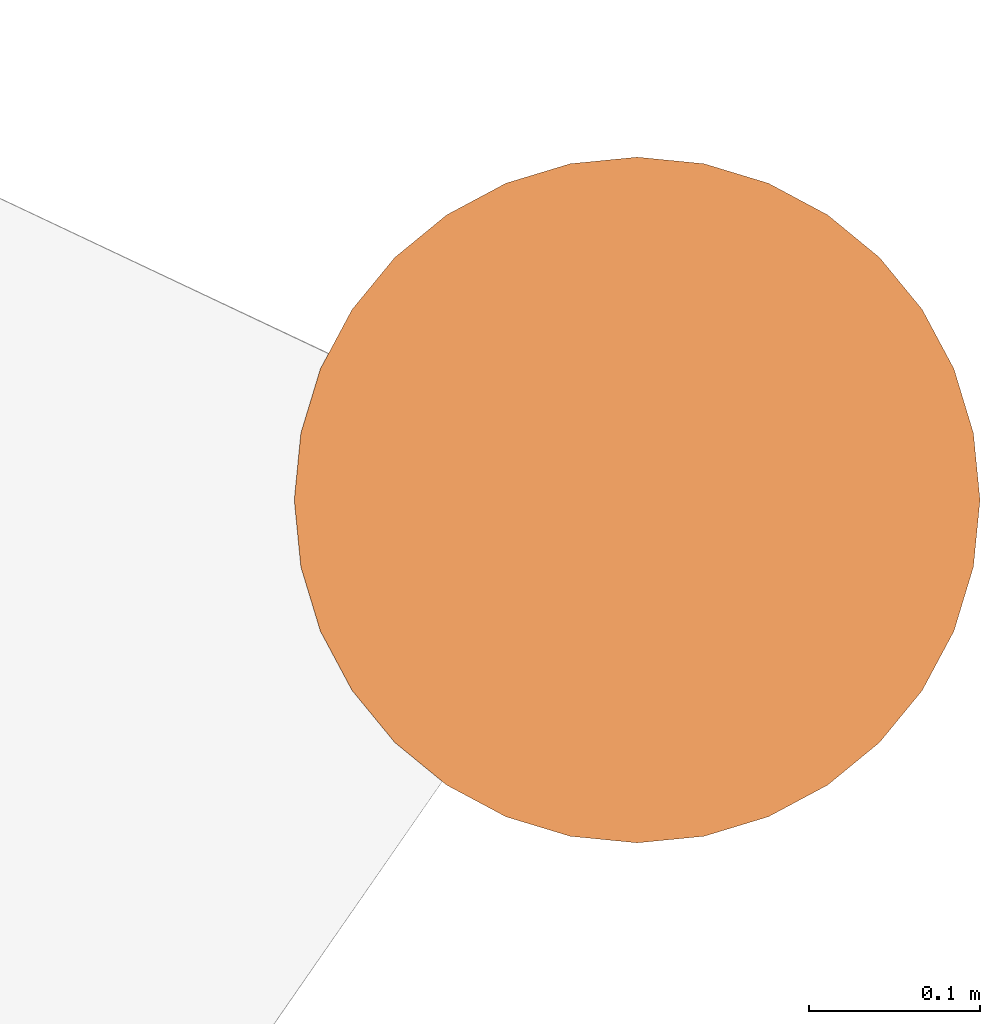
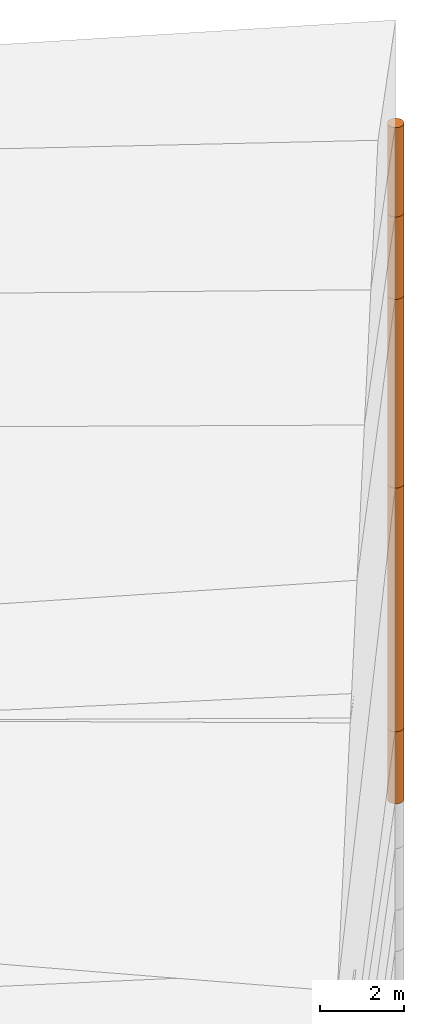
# One storey, part 22 of 24: 5 geographic elements.
"""IFC4 building model written with IfcOpenShell, lengths in metres."""

from ifc_helpers import new_model, entity, si_unit, converted_unit, frame, origin_with_axes, origin_2d_with_axis, place, context, subcontext, project, spatial, polygons, element, save


model = new_model("IFC4")

# Units and contexts
model_context = context("Model", 3, precision=1e-05, world=origin_with_axes())
plan_context = context("Plan", 2, precision=1e-05, world=origin_2d_with_axis())
body_context = subcontext(model_context, "Body", "Model", "MODEL_VIEW")
ifc_project = project(units=[converted_unit("PLANEANGLEUNIT", "degree", entity("IfcReal", 0.0174532925199433), si_unit("PLANEANGLEUNIT", "RADIAN"), dimensions=[0, 0, 0, 0, 0, 0, 0]), si_unit("AREAUNIT", "SQUARE_METRE"), si_unit("VOLUMEUNIT", "CUBIC_METRE"), si_unit("LENGTHUNIT", "METRE")], contexts=[model_context, plan_context])

# Site, building, storey
site_placement = place(None, origin_with_axes())
site = spatial("IfcSite", under=ifc_project, at=site_placement)
building_placement = place(site_placement, origin_with_axes())
building = spatial("IfcBuilding", under=site, at=building_placement, Name="Building")
storey_placement = place(building_placement, origin_with_axes())
storey = spatial("IfcBuildingStorey", under=building, at=storey_placement, Name="Storey")

# Geographic elements
geographic_element_1_placement = place(storey_placement, frame((50.0999984741211, 76.4000015258789, -2.14999914169312), z_axis=(0.0, 0.0, 1.0), x_axis=(1.0, 0.0, 0.0)))
element("IfcGeographicElement", 1, at=geographic_element_1_placement, inside=storey, PredefinedType="NOTDEFINED", context=body_context, shape_type="Tessellation", body=[
    polygons([(0.0, 0.0, -1.04999983310699), (0.0390180610120296, 0.196157038211823, -1.04999983310699), (0.0, 0.199999988079071, -1.04999983310699), (0.0, 0.0, 1.04999983310699), (0.0, 0.199999988079071, 1.04999983310699), (0.0390180610120296, 0.196157038211823, 1.04999983310699), (0.0765366926789284, 0.18477588891983, -1.04999983310699), (0.0765366926789284, 0.18477588891983, 1.04999983310699), (0.111114047467709, 0.166293919086456, -1.04999983310699), (0.111114047467709, 0.166293919086456, 1.04999983310699), (0.141421362757683, 0.141421362757683, -1.04999983310699), (0.141421362757683, 0.141421362757683, 1.04999983310699), (0.166293919086456, 0.111114047467709, -1.04999983310699), (0.166293919086456, 0.111114047467709, 1.04999983310699), (0.18477588891983, 0.0765366926789284, -1.04999983310699), (0.18477588891983, 0.0765366926789284, 1.04999983310699), (0.196157038211823, 0.0390180610120296, -1.04999983310699), (0.196157038211823, 0.0390180610120296, 1.04999983310699), (0.199999988079071, 0.0, -1.04999983310699), (0.199999988079071, 0.0, 1.04999983310699), (0.196157038211823, -0.0390180610120296, -1.04999983310699), (0.196157038211823, -0.0390180610120296, 1.04999983310699), (0.18477588891983, -0.0765366926789284, -1.04999983310699), (0.18477588891983, -0.0765366926789284, 1.04999983310699), (0.166293919086456, -0.111114047467709, -1.04999983310699), (0.166293919086456, -0.111114047467709, 1.04999983310699), (0.141421362757683, -0.141421362757683, -1.04999983310699), (0.141421362757683, -0.141421362757683, 1.04999983310699), (0.111114047467709, -0.166293919086456, -1.04999983310699), (0.111114047467709, -0.166293919086456, 1.04999983310699), (0.0765366926789284, -0.18477588891983, -1.04999983310699), (0.0765366926789284, -0.18477588891983, 1.04999983310699), (0.0390180610120296, -0.196157038211823, -1.04999983310699), (0.0390180610120296, -0.196157038211823, 1.04999983310699), (0.0, -0.199999988079071, -1.04999983310699), (0.0, -0.199999988079071, 1.04999983310699), (-0.0390180610120296, -0.196157038211823, -1.04999983310699), (-0.0390180610120296, -0.196157038211823, 1.04999983310699), (-0.0765366926789284, -0.18477588891983, -1.04999983310699), (-0.0765366926789284, -0.18477588891983, 1.04999983310699), (-0.111114047467709, -0.166293919086456, -1.04999983310699), (-0.111114047467709, -0.166293919086456, 1.04999983310699), (-0.141421362757683, -0.141421362757683, -1.04999983310699), (-0.141421362757683, -0.141421362757683, 1.04999983310699), (-0.166293919086456, -0.111114047467709, -1.04999983310699), (-0.166293919086456, -0.111114047467709, 1.04999983310699), (-0.18477588891983, -0.0765366926789284, -1.04999983310699), (-0.18477588891983, -0.0765366926789284, 1.04999983310699), (-0.196157038211823, -0.0390180610120296, -1.04999983310699), (-0.196157038211823, -0.0390180610120296, 1.04999983310699), (-0.199999988079071, 0.0, -1.04999983310699), (-0.199999988079071, 0.0, 1.04999983310699), (-0.196157038211823, 0.0390180610120296, -1.04999983310699), (-0.196157038211823, 0.0390180610120296, 1.04999983310699), (-0.18477588891983, 0.0765366926789284, -1.04999983310699), (-0.18477588891983, 0.0765366926789284, 1.04999983310699), (-0.166293919086456, 0.111114047467709, -1.04999983310699), (-0.166293919086456, 0.111114047467709, 1.04999983310699), (-0.141421362757683, 0.141421362757683, -1.04999983310699), (-0.141421362757683, 0.141421362757683, 1.04999983310699), (-0.111114047467709, 0.166293919086456, -1.04999983310699), (-0.111114047467709, 0.166293919086456, 1.04999983310699), (-0.0765366926789284, 0.18477588891983, -1.04999983310699), (-0.0765366926789284, 0.18477588891983, 1.04999983310699), (-0.0390180610120296, 0.196157038211823, -1.04999983310699), (-0.0390180610120296, 0.196157038211823, 1.04999983310699)], [[[3, 2, 1]], [[6, 5, 4]], [[34, 36, 35, 33]], [[2, 7, 1]], [[8, 6, 4]], [[54, 56, 55, 53]], [[7, 9, 1]], [[10, 8, 4]], [[10, 12, 11, 9]], [[9, 11, 1]], [[12, 10, 4]], [[11, 13, 1]], [[12, 4, 14]], [[46, 48, 47, 45]], [[1, 13, 15]], [[4, 16, 14]], [[28, 30, 29, 27]], [[1, 15, 17]], [[16, 4, 18]], [[38, 40, 39, 37]], [[1, 17, 19]], [[4, 20, 18]], [[20, 22, 21, 19]], [[1, 19, 21]], [[20, 4, 22]], [[22, 24, 23, 21]], [[1, 21, 23]], [[22, 4, 24]], [[5, 6, 2, 3]], [[1, 23, 25]], [[24, 4, 26]], [[58, 60, 59, 57]], [[1, 25, 27]], [[26, 4, 28]], [[24, 26, 25, 23]], [[1, 27, 29]], [[28, 4, 30]], [[8, 10, 9, 7]], [[1, 29, 31]], [[4, 32, 30]], [[60, 62, 61, 59]], [[1, 31, 33]], [[4, 34, 32]], [[64, 66, 65, 63]], [[1, 33, 35]], [[4, 36, 34]], [[26, 28, 27, 25]], [[1, 35, 37]], [[4, 38, 36]], [[32, 34, 33, 31]], [[1, 37, 39]], [[4, 40, 38]], [[36, 38, 37, 35]], [[1, 39, 41]], [[4, 42, 40]], [[42, 44, 43, 41]], [[43, 1, 41]], [[4, 44, 42]], [[44, 46, 45, 43]], [[45, 1, 43]], [[4, 46, 44]], [[12, 14, 13, 11]], [[47, 1, 45]], [[48, 46, 4]], [[14, 16, 15, 13]], [[49, 1, 47]], [[4, 50, 48]], [[50, 52, 51, 49]], [[51, 1, 49]], [[52, 50, 4]], [[66, 5, 3, 65]], [[51, 53, 1]], [[4, 54, 52]], [[6, 8, 7, 2]], [[55, 1, 53]], [[4, 56, 54]], [[16, 18, 17, 15]], [[55, 57, 1]], [[4, 58, 56]], [[30, 32, 31, 29]], [[59, 1, 57]], [[60, 58, 4]], [[56, 58, 57, 55]], [[59, 61, 1]], [[62, 60, 4]], [[62, 64, 63, 61]], [[61, 63, 1]], [[64, 62, 4]], [[40, 42, 41, 39]], [[63, 65, 1]], [[66, 64, 4]], [[18, 20, 19, 17]], [[65, 3, 1]], [[5, 66, 4]], [[52, 54, 53, 51]], [[48, 50, 49, 47]]]),
])
geographic_element_2_placement = place(storey_placement, frame((50.0999984741211, 76.4000015258789, 2.45000076293945), z_axis=(0.0, 0.0, 1.0), x_axis=(1.0, 0.0, 0.0)))
element("IfcGeographicElement", 2, at=geographic_element_2_placement, inside=storey, PredefinedType="NOTDEFINED", context=body_context, shape_type="Tessellation", body=[
    polygons([(0.0, 0.0, -3.54999971389771), (0.0390180610120296, 0.196157038211823, -3.54999971389771), (0.0, 0.199999988079071, -3.54999971389771), (0.0, 0.0, 3.54999971389771), (0.0, 0.199999988079071, 3.54999971389771), (0.0390180610120296, 0.196157038211823, 3.54999971389771), (0.0765366926789284, 0.18477588891983, -3.54999971389771), (0.0765366926789284, 0.18477588891983, 3.54999971389771), (0.111114047467709, 0.166293919086456, -3.54999971389771), (0.111114047467709, 0.166293919086456, 3.54999971389771), (0.141421362757683, 0.141421362757683, -3.54999971389771), (0.141421362757683, 0.141421362757683, 3.54999971389771), (0.166293919086456, 0.111114047467709, -3.54999971389771), (0.166293919086456, 0.111114047467709, 3.54999971389771), (0.18477588891983, 0.0765366926789284, -3.54999971389771), (0.18477588891983, 0.0765366926789284, 3.54999971389771), (0.196157038211823, 0.0390180610120296, -3.54999971389771), (0.196157038211823, 0.0390180610120296, 3.54999971389771), (0.199999988079071, 0.0, -3.54999971389771), (0.199999988079071, 0.0, 3.54999971389771), (0.196157038211823, -0.0390180610120296, -3.54999971389771), (0.196157038211823, -0.0390180610120296, 3.54999971389771), (0.18477588891983, -0.0765366926789284, -3.54999971389771), (0.18477588891983, -0.0765366926789284, 3.54999971389771), (0.166293919086456, -0.111114047467709, -3.54999971389771), (0.166293919086456, -0.111114047467709, 3.54999971389771), (0.141421362757683, -0.141421362757683, -3.54999971389771), (0.141421362757683, -0.141421362757683, 3.54999971389771), (0.111114047467709, -0.166293919086456, -3.54999971389771), (0.111114047467709, -0.166293919086456, 3.54999971389771), (0.0765366926789284, -0.18477588891983, -3.54999971389771), (0.0765366926789284, -0.18477588891983, 3.54999971389771), (0.0390180610120296, -0.196157038211823, -3.54999971389771), (0.0390180610120296, -0.196157038211823, 3.54999971389771), (0.0, -0.199999988079071, -3.54999971389771), (0.0, -0.199999988079071, 3.54999971389771), (-0.0390180610120296, -0.196157038211823, -3.54999971389771), (-0.0390180610120296, -0.196157038211823, 3.54999971389771), (-0.0765366926789284, -0.18477588891983, -3.54999971389771), (-0.0765366926789284, -0.18477588891983, 3.54999971389771), (-0.111114047467709, -0.166293919086456, -3.54999971389771), (-0.111114047467709, -0.166293919086456, 3.54999971389771), (-0.141421362757683, -0.141421362757683, -3.54999971389771), (-0.141421362757683, -0.141421362757683, 3.54999971389771), (-0.166293919086456, -0.111114047467709, -3.54999971389771), (-0.166293919086456, -0.111114047467709, 3.54999971389771), (-0.18477588891983, -0.0765366926789284, -3.54999971389771), (-0.18477588891983, -0.0765366926789284, 3.54999971389771), (-0.196157038211823, -0.0390180610120296, -3.54999971389771), (-0.196157038211823, -0.0390180610120296, 3.54999971389771), (-0.199999988079071, 0.0, -3.54999971389771), (-0.199999988079071, 0.0, 3.54999971389771), (-0.196157038211823, 0.0390180610120296, -3.54999971389771), (-0.196157038211823, 0.0390180610120296, 3.54999971389771), (-0.18477588891983, 0.0765366926789284, -3.54999971389771), (-0.18477588891983, 0.0765366926789284, 3.54999971389771), (-0.166293919086456, 0.111114047467709, -3.54999971389771), (-0.166293919086456, 0.111114047467709, 3.54999971389771), (-0.141421362757683, 0.141421362757683, -3.54999971389771), (-0.141421362757683, 0.141421362757683, 3.54999971389771), (-0.111114047467709, 0.166293919086456, -3.54999971389771), (-0.111114047467709, 0.166293919086456, 3.54999971389771), (-0.0765366926789284, 0.18477588891983, -3.54999971389771), (-0.0765366926789284, 0.18477588891983, 3.54999971389771), (-0.0390180610120296, 0.196157038211823, -3.54999971389771), (-0.0390180610120296, 0.196157038211823, 3.54999971389771)], [[[3, 2, 1]], [[6, 5, 4]], [[32, 34, 33, 31]], [[2, 7, 1]], [[8, 6, 4]], [[64, 66, 65, 63]], [[7, 9, 1]], [[10, 8, 4]], [[9, 11, 1]], [[12, 10, 4]], [[40, 42, 41, 39]], [[1, 11, 13]], [[12, 4, 14]], [[10, 12, 11, 9]], [[1, 13, 15]], [[14, 4, 16]], [[12, 14, 13, 11]], [[1, 15, 17]], [[16, 4, 18]], [[18, 20, 19, 17]], [[1, 17, 19]], [[4, 20, 18]], [[20, 22, 21, 19]], [[1, 19, 21]], [[20, 4, 22]], [[22, 24, 23, 21]], [[1, 21, 23]], [[4, 24, 22]], [[54, 56, 55, 53]], [[1, 23, 25]], [[4, 26, 24]], [[56, 58, 57, 55]], [[1, 25, 27]], [[4, 28, 26]], [[24, 26, 25, 23]], [[1, 27, 29]], [[28, 4, 30]], [[26, 28, 27, 25]], [[1, 29, 31]], [[4, 32, 30]], [[46, 48, 47, 45]], [[1, 31, 33]], [[4, 34, 32]], [[36, 38, 37, 35]], [[1, 33, 35]], [[4, 36, 34]], [[42, 44, 43, 41]], [[1, 35, 37]], [[4, 38, 36]], [[38, 40, 39, 37]], [[1, 37, 39]], [[4, 40, 38]], [[34, 36, 35, 33]], [[1, 39, 41]], [[4, 42, 40]], [[8, 10, 9, 7]], [[43, 1, 41]], [[4, 44, 42]], [[44, 46, 45, 43]], [[43, 45, 1]], [[4, 46, 44]], [[30, 32, 31, 29]], [[45, 47, 1]], [[4, 48, 46]], [[28, 30, 29, 27]], [[47, 49, 1]], [[4, 50, 48]], [[5, 6, 2, 3]], [[51, 1, 49]], [[52, 50, 4]], [[48, 50, 49, 47]], [[51, 53, 1]], [[4, 54, 52]], [[50, 52, 51, 49]], [[55, 1, 53]], [[56, 54, 4]], [[52, 54, 53, 51]], [[57, 1, 55]], [[58, 56, 4]], [[58, 60, 59, 57]], [[59, 1, 57]], [[60, 58, 4]], [[60, 62, 61, 59]], [[59, 61, 1]], [[62, 60, 4]], [[62, 64, 63, 61]], [[61, 63, 1]], [[64, 62, 4]], [[14, 16, 15, 13]], [[63, 65, 1]], [[66, 64, 4]], [[16, 18, 17, 15]], [[65, 3, 1]], [[5, 66, 4]], [[6, 8, 7, 2]], [[66, 5, 3, 65]]]),
])
geographic_element_3_placement = place(storey_placement, frame((50.0999984741211, 76.4000015258789, 8.75000095367432), z_axis=(0.0, 0.0, 1.0), x_axis=(1.0, 0.0, 0.0)))
element("IfcGeographicElement", 3, at=geographic_element_3_placement, inside=storey, PredefinedType="NOTDEFINED", context=body_context, shape_type="Tessellation", body=[
    polygons([(0.0, 0.0, -2.74999976158142), (0.0390180610120296, 0.196157038211823, -2.74999976158142), (0.0, 0.199999988079071, -2.74999976158142), (0.0, 0.0, 2.74999976158142), (0.0, 0.199999988079071, 2.74999976158142), (0.0390180610120296, 0.196157038211823, 2.74999976158142), (0.0765366926789284, 0.18477588891983, -2.74999976158142), (0.0765366926789284, 0.18477588891983, 2.74999976158142), (0.111114047467709, 0.166293919086456, -2.74999976158142), (0.111114047467709, 0.166293919086456, 2.74999976158142), (0.141421362757683, 0.141421362757683, -2.74999976158142), (0.141421362757683, 0.141421362757683, 2.74999976158142), (0.166293919086456, 0.111114047467709, -2.74999976158142), (0.166293919086456, 0.111114047467709, 2.74999976158142), (0.18477588891983, 0.0765366926789284, -2.74999976158142), (0.18477588891983, 0.0765366926789284, 2.74999976158142), (0.196157038211823, 0.0390180610120296, -2.74999976158142), (0.196157038211823, 0.0390180610120296, 2.74999976158142), (0.199999988079071, 0.0, -2.74999976158142), (0.199999988079071, 0.0, 2.74999976158142), (0.196157038211823, -0.0390180610120296, -2.74999976158142), (0.196157038211823, -0.0390180610120296, 2.74999976158142), (0.18477588891983, -0.0765366926789284, -2.74999976158142), (0.18477588891983, -0.0765366926789284, 2.74999976158142), (0.166293919086456, -0.111114047467709, -2.74999976158142), (0.166293919086456, -0.111114047467709, 2.74999976158142), (0.141421362757683, -0.141421362757683, -2.74999976158142), (0.141421362757683, -0.141421362757683, 2.74999976158142), (0.111114047467709, -0.166293919086456, -2.74999976158142), (0.111114047467709, -0.166293919086456, 2.74999976158142), (0.0765366926789284, -0.18477588891983, -2.74999976158142), (0.0765366926789284, -0.18477588891983, 2.74999976158142), (0.0390180610120296, -0.196157038211823, -2.74999976158142), (0.0390180610120296, -0.196157038211823, 2.74999976158142), (0.0, -0.199999988079071, -2.74999976158142), (0.0, -0.199999988079071, 2.74999976158142), (-0.0390180610120296, -0.196157038211823, -2.74999976158142), (-0.0390180610120296, -0.196157038211823, 2.74999976158142), (-0.0765366926789284, -0.18477588891983, -2.74999976158142), (-0.0765366926789284, -0.18477588891983, 2.74999976158142), (-0.111114047467709, -0.166293919086456, -2.74999976158142), (-0.111114047467709, -0.166293919086456, 2.74999976158142), (-0.141421362757683, -0.141421362757683, -2.74999976158142), (-0.141421362757683, -0.141421362757683, 2.74999976158142), (-0.166293919086456, -0.111114047467709, -2.74999976158142), (-0.166293919086456, -0.111114047467709, 2.74999976158142), (-0.18477588891983, -0.0765366926789284, -2.74999976158142), (-0.18477588891983, -0.0765366926789284, 2.74999976158142), (-0.196157038211823, -0.0390180610120296, -2.74999976158142), (-0.196157038211823, -0.0390180610120296, 2.74999976158142), (-0.199999988079071, 0.0, -2.74999976158142), (-0.199999988079071, 0.0, 2.74999976158142), (-0.196157038211823, 0.0390180610120296, -2.74999976158142), (-0.196157038211823, 0.0390180610120296, 2.74999976158142), (-0.18477588891983, 0.0765366926789284, -2.74999976158142), (-0.18477588891983, 0.0765366926789284, 2.74999976158142), (-0.166293919086456, 0.111114047467709, -2.74999976158142), (-0.166293919086456, 0.111114047467709, 2.74999976158142), (-0.141421362757683, 0.141421362757683, -2.74999976158142), (-0.141421362757683, 0.141421362757683, 2.74999976158142), (-0.111114047467709, 0.166293919086456, -2.74999976158142), (-0.111114047467709, 0.166293919086456, 2.74999976158142), (-0.0765366926789284, 0.18477588891983, -2.74999976158142), (-0.0765366926789284, 0.18477588891983, 2.74999976158142), (-0.0390180610120296, 0.196157038211823, -2.74999976158142), (-0.0390180610120296, 0.196157038211823, 2.74999976158142)], [[[3, 2, 1]], [[6, 5, 4]], [[28, 30, 29, 27]], [[2, 7, 1]], [[8, 6, 4]], [[64, 66, 65, 63]], [[7, 9, 1]], [[10, 8, 4]], [[9, 11, 1]], [[12, 10, 4]], [[6, 8, 7, 2]], [[1, 11, 13]], [[12, 4, 14]], [[66, 5, 3, 65]], [[1, 13, 15]], [[4, 16, 14]], [[12, 14, 13, 11]], [[1, 15, 17]], [[16, 4, 18]], [[14, 16, 15, 13]], [[1, 17, 19]], [[4, 20, 18]], [[16, 18, 17, 15]], [[1, 19, 21]], [[20, 4, 22]], [[18, 20, 19, 17]], [[1, 21, 23]], [[4, 24, 22]], [[20, 22, 21, 19]], [[1, 23, 25]], [[4, 26, 24]], [[22, 24, 23, 21]], [[1, 25, 27]], [[4, 28, 26]], [[24, 26, 25, 23]], [[1, 27, 29]], [[28, 4, 30]], [[26, 28, 27, 25]], [[1, 29, 31]], [[4, 32, 30]], [[5, 6, 2, 3]], [[1, 31, 33]], [[4, 34, 32]], [[30, 32, 31, 29]], [[1, 33, 35]], [[4, 36, 34]], [[8, 10, 9, 7]], [[1, 35, 37]], [[4, 38, 36]], [[32, 34, 33, 31]], [[1, 37, 39]], [[4, 40, 38]], [[36, 38, 37, 35]], [[1, 39, 41]], [[4, 42, 40]], [[38, 40, 39, 37]], [[43, 1, 41]], [[4, 44, 42]], [[40, 42, 41, 39]], [[43, 45, 1]], [[4, 46, 44]], [[42, 44, 43, 41]], [[45, 47, 1]], [[48, 46, 4]], [[44, 46, 45, 43]], [[47, 49, 1]], [[4, 50, 48]], [[46, 48, 47, 45]], [[51, 1, 49]], [[52, 50, 4]], [[48, 50, 49, 47]], [[51, 53, 1]], [[4, 54, 52]], [[50, 52, 51, 49]], [[55, 1, 53]], [[56, 54, 4]], [[52, 54, 53, 51]], [[55, 57, 1]], [[58, 56, 4]], [[54, 56, 55, 53]], [[59, 1, 57]], [[60, 58, 4]], [[56, 58, 57, 55]], [[59, 61, 1]], [[62, 60, 4]], [[58, 60, 59, 57]], [[61, 63, 1]], [[64, 62, 4]], [[60, 62, 61, 59]], [[63, 65, 1]], [[66, 64, 4]], [[62, 64, 63, 61]], [[65, 3, 1]], [[5, 66, 4]], [[34, 36, 35, 33]], [[10, 12, 11, 9]]]),
])
geographic_element_4_placement = place(storey_placement, frame((50.0999984741211, 76.4000015258789, 12.7000007629395), z_axis=(0.0, 0.0, 1.0), x_axis=(1.0, 0.0, 0.0)))
element("IfcGeographicElement", 4, at=geographic_element_4_placement, inside=storey, PredefinedType="NOTDEFINED", context=body_context, shape_type="Tessellation", body=[
    polygons([(0.0, 0.0, -1.19999992847443), (0.0390180610120296, 0.196157038211823, -1.19999992847443), (0.0, 0.199999988079071, -1.19999992847443), (0.0, 0.0, 1.19999992847443), (0.0, 0.199999988079071, 1.19999992847443), (0.0390180610120296, 0.196157038211823, 1.19999992847443), (0.0765366926789284, 0.18477588891983, -1.19999992847443), (0.0765366926789284, 0.18477588891983, 1.19999992847443), (0.111114047467709, 0.166293919086456, -1.19999992847443), (0.111114047467709, 0.166293919086456, 1.19999992847443), (0.141421362757683, 0.141421362757683, -1.19999992847443), (0.141421362757683, 0.141421362757683, 1.19999992847443), (0.166293919086456, 0.111114047467709, -1.19999992847443), (0.166293919086456, 0.111114047467709, 1.19999992847443), (0.18477588891983, 0.0765366926789284, -1.19999992847443), (0.18477588891983, 0.0765366926789284, 1.19999992847443), (0.196157038211823, 0.0390180610120296, -1.19999992847443), (0.196157038211823, 0.0390180610120296, 1.19999992847443), (0.199999988079071, 0.0, -1.19999992847443), (0.199999988079071, 0.0, 1.19999992847443), (0.196157038211823, -0.0390180610120296, -1.19999992847443), (0.196157038211823, -0.0390180610120296, 1.19999992847443), (0.18477588891983, -0.0765366926789284, -1.19999992847443), (0.18477588891983, -0.0765366926789284, 1.19999992847443), (0.166293919086456, -0.111114047467709, -1.19999992847443), (0.166293919086456, -0.111114047467709, 1.19999992847443), (0.141421362757683, -0.141421362757683, -1.19999992847443), (0.141421362757683, -0.141421362757683, 1.19999992847443), (0.111114047467709, -0.166293919086456, -1.19999992847443), (0.111114047467709, -0.166293919086456, 1.19999992847443), (0.0765366926789284, -0.18477588891983, -1.19999992847443), (0.0765366926789284, -0.18477588891983, 1.19999992847443), (0.0390180610120296, -0.196157038211823, -1.19999992847443), (0.0390180610120296, -0.196157038211823, 1.19999992847443), (0.0, -0.199999988079071, -1.19999992847443), (0.0, -0.199999988079071, 1.19999992847443), (-0.0390180610120296, -0.196157038211823, -1.19999992847443), (-0.0390180610120296, -0.196157038211823, 1.19999992847443), (-0.0765366926789284, -0.18477588891983, -1.19999992847443), (-0.0765366926789284, -0.18477588891983, 1.19999992847443), (-0.111114047467709, -0.166293919086456, -1.19999992847443), (-0.111114047467709, -0.166293919086456, 1.19999992847443), (-0.141421362757683, -0.141421362757683, -1.19999992847443), (-0.141421362757683, -0.141421362757683, 1.19999992847443), (-0.166293919086456, -0.111114047467709, -1.19999992847443), (-0.166293919086456, -0.111114047467709, 1.19999992847443), (-0.18477588891983, -0.0765366926789284, -1.19999992847443), (-0.18477588891983, -0.0765366926789284, 1.19999992847443), (-0.196157038211823, -0.0390180610120296, -1.19999992847443), (-0.196157038211823, -0.0390180610120296, 1.19999992847443), (-0.199999988079071, 0.0, -1.19999992847443), (-0.199999988079071, 0.0, 1.19999992847443), (-0.196157038211823, 0.0390180610120296, -1.19999992847443), (-0.196157038211823, 0.0390180610120296, 1.19999992847443), (-0.18477588891983, 0.0765366926789284, -1.19999992847443), (-0.18477588891983, 0.0765366926789284, 1.19999992847443), (-0.166293919086456, 0.111114047467709, -1.19999992847443), (-0.166293919086456, 0.111114047467709, 1.19999992847443), (-0.141421362757683, 0.141421362757683, -1.19999992847443), (-0.141421362757683, 0.141421362757683, 1.19999992847443), (-0.111114047467709, 0.166293919086456, -1.19999992847443), (-0.111114047467709, 0.166293919086456, 1.19999992847443), (-0.0765366926789284, 0.18477588891983, -1.19999992847443), (-0.0765366926789284, 0.18477588891983, 1.19999992847443), (-0.0390180610120296, 0.196157038211823, -1.19999992847443), (-0.0390180610120296, 0.196157038211823, 1.19999992847443)], [[[3, 2, 1]], [[6, 5, 4]], [[62, 64, 63, 61]], [[2, 7, 1]], [[8, 6, 4]], [[30, 32, 31, 29]], [[7, 9, 1]], [[10, 8, 4]], [[10, 12, 11, 9]], [[9, 11, 1]], [[12, 10, 4]], [[11, 13, 1]], [[12, 4, 14]], [[66, 5, 3, 65]], [[1, 13, 15]], [[4, 16, 14]], [[42, 44, 43, 41]], [[1, 15, 17]], [[16, 4, 18]], [[48, 50, 49, 47]], [[1, 17, 19]], [[4, 20, 18]], [[16, 18, 17, 15]], [[1, 19, 21]], [[20, 4, 22]], [[50, 52, 51, 49]], [[1, 21, 23]], [[22, 4, 24]], [[54, 56, 55, 53]], [[1, 23, 25]], [[4, 26, 24]], [[56, 58, 57, 55]], [[27, 1, 25]], [[26, 4, 28]], [[58, 60, 59, 57]], [[1, 27, 29]], [[28, 4, 30]], [[60, 62, 61, 59]], [[1, 29, 31]], [[4, 32, 30]], [[64, 66, 65, 63]], [[1, 31, 33]], [[4, 34, 32]], [[6, 8, 7, 2]], [[1, 33, 35]], [[4, 36, 34]], [[8, 10, 9, 7]], [[1, 35, 37]], [[4, 38, 36]], [[32, 34, 33, 31]], [[1, 37, 39]], [[4, 40, 38]], [[36, 38, 37, 35]], [[1, 39, 41]], [[4, 42, 40]], [[46, 48, 47, 45]], [[43, 1, 41]], [[4, 44, 42]], [[34, 36, 35, 33]], [[45, 1, 43]], [[46, 44, 4]], [[14, 16, 15, 13]], [[45, 47, 1]], [[48, 46, 4]], [[44, 46, 45, 43]], [[49, 1, 47]], [[4, 50, 48]], [[40, 42, 41, 39]], [[51, 1, 49]], [[52, 50, 4]], [[18, 20, 19, 17]], [[51, 53, 1]], [[4, 54, 52]], [[20, 22, 21, 19]], [[55, 1, 53]], [[4, 56, 54]], [[52, 54, 53, 51]], [[55, 57, 1]], [[58, 56, 4]], [[22, 24, 23, 21]], [[57, 59, 1]], [[60, 58, 4]], [[24, 26, 25, 23]], [[59, 61, 1]], [[62, 60, 4]], [[26, 28, 27, 25]], [[61, 63, 1]], [[64, 62, 4]], [[28, 30, 29, 27]], [[63, 65, 1]], [[66, 64, 4]], [[5, 6, 2, 3]], [[65, 3, 1]], [[5, 66, 4]], [[38, 40, 39, 37]], [[12, 14, 13, 11]]]),
])
geographic_element_5_placement = place(storey_placement, frame((50.0999984741211, 76.4000015258789, 15.2000007629395), z_axis=(0.0, 0.0, 1.0), x_axis=(1.0, 0.0, 0.0)))
element("IfcGeographicElement", 5, at=geographic_element_5_placement, inside=storey, PredefinedType="NOTDEFINED", context=body_context, shape_type="Tessellation", body=[
    polygons([(0.0, 0.0, -1.29999983310699), (0.0390180610120296, 0.196157038211823, -1.29999983310699), (0.0, 0.199999988079071, -1.29999983310699), (0.0, 0.0, 1.29999983310699), (0.0, 0.199999988079071, 1.29999983310699), (0.0390180610120296, 0.196157038211823, 1.29999983310699), (0.0765366926789284, 0.18477588891983, -1.29999983310699), (0.0765366926789284, 0.18477588891983, 1.29999983310699), (0.111114047467709, 0.166293919086456, -1.29999983310699), (0.111114047467709, 0.166293919086456, 1.29999983310699), (0.141421362757683, 0.141421362757683, -1.29999983310699), (0.141421362757683, 0.141421362757683, 1.29999983310699), (0.166293919086456, 0.111114047467709, -1.29999983310699), (0.166293919086456, 0.111114047467709, 1.29999983310699), (0.18477588891983, 0.0765366926789284, -1.29999983310699), (0.18477588891983, 0.0765366926789284, 1.29999983310699), (0.196157038211823, 0.0390180610120296, -1.29999983310699), (0.196157038211823, 0.0390180610120296, 1.29999983310699), (0.199999988079071, 0.0, -1.29999983310699), (0.199999988079071, 0.0, 1.29999983310699), (0.196157038211823, -0.0390180610120296, -1.29999983310699), (0.196157038211823, -0.0390180610120296, 1.29999983310699), (0.18477588891983, -0.0765366926789284, -1.29999983310699), (0.18477588891983, -0.0765366926789284, 1.29999983310699), (0.166293919086456, -0.111114047467709, -1.29999983310699), (0.166293919086456, -0.111114047467709, 1.29999983310699), (0.141421362757683, -0.141421362757683, -1.29999983310699), (0.141421362757683, -0.141421362757683, 1.29999983310699), (0.111114047467709, -0.166293919086456, -1.29999983310699), (0.111114047467709, -0.166293919086456, 1.29999983310699), (0.0765366926789284, -0.18477588891983, -1.29999983310699), (0.0765366926789284, -0.18477588891983, 1.29999983310699), (0.0390180610120296, -0.196157038211823, -1.29999983310699), (0.0390180610120296, -0.196157038211823, 1.29999983310699), (0.0, -0.199999988079071, -1.29999983310699), (0.0, -0.199999988079071, 1.29999983310699), (-0.0390180610120296, -0.196157038211823, -1.29999983310699), (-0.0390180610120296, -0.196157038211823, 1.29999983310699), (-0.0765366926789284, -0.18477588891983, -1.29999983310699), (-0.0765366926789284, -0.18477588891983, 1.29999983310699), (-0.111114047467709, -0.166293919086456, -1.29999983310699), (-0.111114047467709, -0.166293919086456, 1.29999983310699), (-0.141421362757683, -0.141421362757683, -1.29999983310699), (-0.141421362757683, -0.141421362757683, 1.29999983310699), (-0.166293919086456, -0.111114047467709, -1.29999983310699), (-0.166293919086456, -0.111114047467709, 1.29999983310699), (-0.18477588891983, -0.0765366926789284, -1.29999983310699), (-0.18477588891983, -0.0765366926789284, 1.29999983310699), (-0.196157038211823, -0.0390180610120296, -1.29999983310699), (-0.196157038211823, -0.0390180610120296, 1.29999983310699), (-0.199999988079071, 0.0, -1.29999983310699), (-0.199999988079071, 0.0, 1.29999983310699), (-0.196157038211823, 0.0390180610120296, -1.29999983310699), (-0.196157038211823, 0.0390180610120296, 1.29999983310699), (-0.18477588891983, 0.0765366926789284, -1.29999983310699), (-0.18477588891983, 0.0765366926789284, 1.29999983310699), (-0.166293919086456, 0.111114047467709, -1.29999983310699), (-0.166293919086456, 0.111114047467709, 1.29999983310699), (-0.141421362757683, 0.141421362757683, -1.29999983310699), (-0.141421362757683, 0.141421362757683, 1.29999983310699), (-0.111114047467709, 0.166293919086456, -1.29999983310699), (-0.111114047467709, 0.166293919086456, 1.29999983310699), (-0.0765366926789284, 0.18477588891983, -1.29999983310699), (-0.0765366926789284, 0.18477588891983, 1.29999983310699), (-0.0390180610120296, 0.196157038211823, -1.29999983310699), (-0.0390180610120296, 0.196157038211823, 1.29999983310699)], [[[3, 2, 1]], [[6, 5, 4]], [[32, 34, 33, 31]], [[2, 7, 1]], [[8, 6, 4]], [[64, 66, 65, 63]], [[7, 9, 1]], [[10, 8, 4]], [[9, 11, 1]], [[12, 10, 4]], [[40, 42, 41, 39]], [[1, 11, 13]], [[12, 4, 14]], [[10, 12, 11, 9]], [[1, 13, 15]], [[4, 16, 14]], [[12, 14, 13, 11]], [[1, 15, 17]], [[4, 18, 16]], [[18, 20, 19, 17]], [[1, 17, 19]], [[18, 4, 20]], [[20, 22, 21, 19]], [[1, 19, 21]], [[20, 4, 22]], [[22, 24, 23, 21]], [[1, 21, 23]], [[4, 24, 22]], [[54, 56, 55, 53]], [[1, 23, 25]], [[4, 26, 24]], [[56, 58, 57, 55]], [[27, 1, 25]], [[4, 28, 26]], [[24, 26, 25, 23]], [[1, 27, 29]], [[28, 4, 30]], [[26, 28, 27, 25]], [[1, 29, 31]], [[4, 32, 30]], [[46, 48, 47, 45]], [[1, 31, 33]], [[4, 34, 32]], [[36, 38, 37, 35]], [[1, 33, 35]], [[4, 36, 34]], [[42, 44, 43, 41]], [[1, 35, 37]], [[4, 38, 36]], [[38, 40, 39, 37]], [[1, 37, 39]], [[4, 40, 38]], [[34, 36, 35, 33]], [[1, 39, 41]], [[4, 42, 40]], [[8, 10, 9, 7]], [[43, 1, 41]], [[4, 44, 42]], [[44, 46, 45, 43]], [[43, 45, 1]], [[46, 44, 4]], [[30, 32, 31, 29]], [[45, 47, 1]], [[48, 46, 4]], [[28, 30, 29, 27]], [[47, 49, 1]], [[50, 48, 4]], [[5, 6, 2, 3]], [[51, 1, 49]], [[4, 52, 50]], [[48, 50, 49, 47]], [[53, 1, 51]], [[4, 54, 52]], [[50, 52, 51, 49]], [[53, 55, 1]], [[56, 54, 4]], [[52, 54, 53, 51]], [[55, 57, 1]], [[58, 56, 4]], [[58, 60, 59, 57]], [[57, 59, 1]], [[60, 58, 4]], [[60, 62, 61, 59]], [[59, 61, 1]], [[62, 60, 4]], [[62, 64, 63, 61]], [[61, 63, 1]], [[64, 62, 4]], [[14, 16, 15, 13]], [[63, 65, 1]], [[66, 64, 4]], [[16, 18, 17, 15]], [[65, 3, 1]], [[5, 66, 4]], [[6, 8, 7, 2]], [[66, 5, 3, 65]]]),
])

save(model, "model.ifc")
